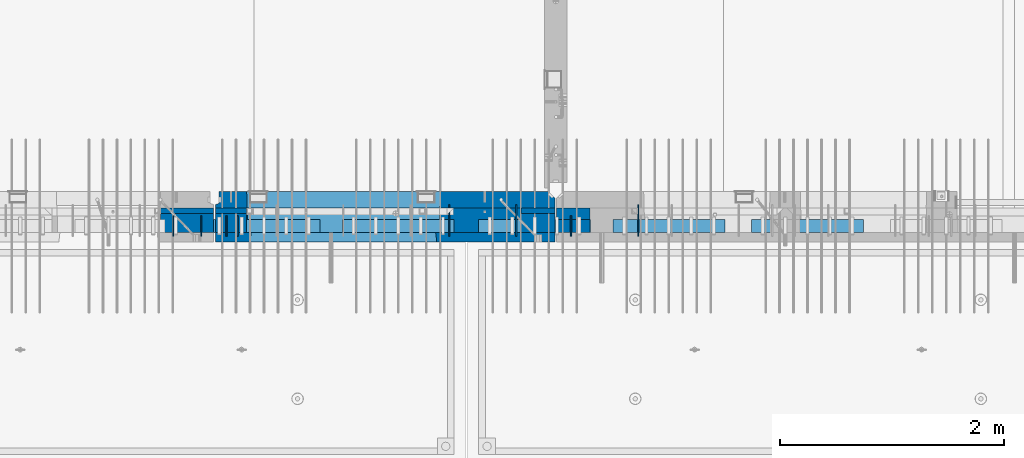
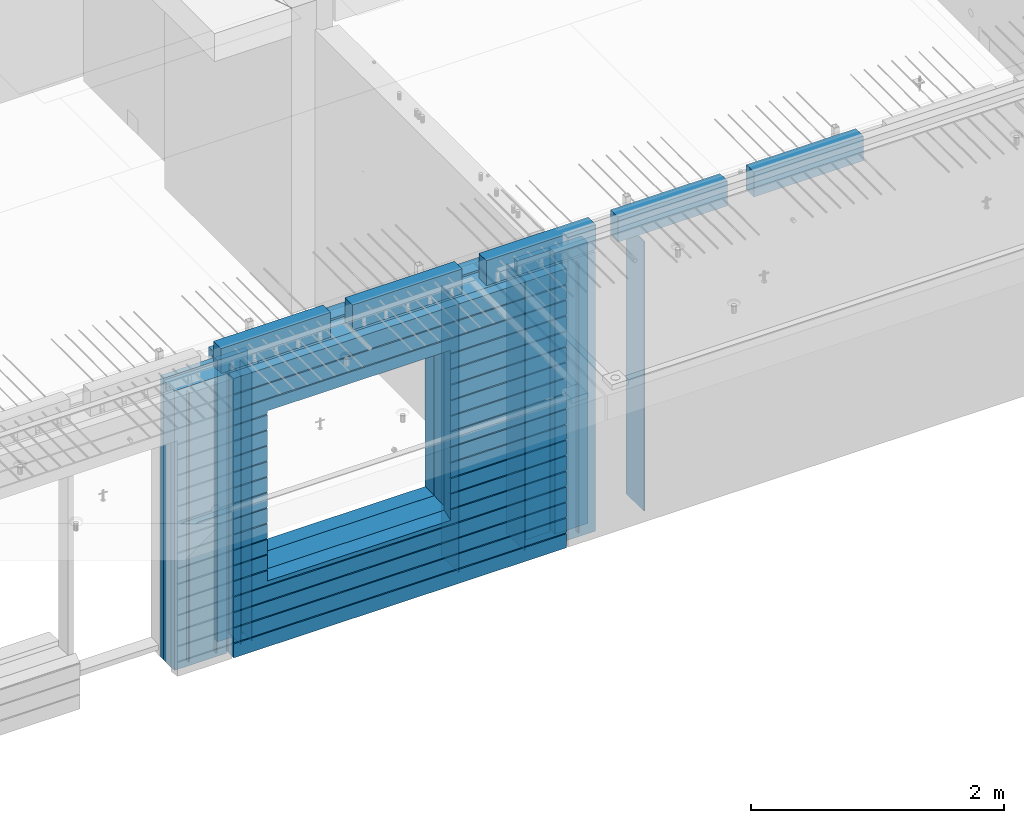
# One storey, part 233 of 352: 24 walls, 10 elements without a shape of their own.
"""IFC2X3 building model written with IfcOpenShell, lengths in millimetres."""

from ifc_helpers import new_model, si_unit, frame, origin_with_axes, place, context, subcontext, project, spatial, faceted_brep, material, type_object, element, aggregate, save


model = new_model("IFC2X3")

# Units and contexts
model_context = context("Model", 3, precision=1e-05, world=origin_with_axes())
body_context = subcontext(model_context, "Body", "Model", "MODEL_VIEW")
ifc_project = project(units=[si_unit("LENGTHUNIT", "METRE", prefix="MILLI"), si_unit("AREAUNIT", "SQUARE_METRE"), si_unit("VOLUMEUNIT", "CUBIC_METRE"), si_unit("MASSUNIT", "GRAM", prefix="KILO"), si_unit("TIMEUNIT", "SECOND"), si_unit("PLANEANGLEUNIT", "RADIAN"), si_unit("SOLIDANGLEUNIT", "STERADIAN"), si_unit("THERMODYNAMICTEMPERATUREUNIT", "DEGREE_CELSIUS"), si_unit("LUMINOUSINTENSITYUNIT", "LUMEN")], contexts=[model_context])

# Site, building, storey
site_placement = place(None, origin_with_axes())
site = spatial("IfcSite", under=ifc_project, at=site_placement, CompositionType="ELEMENT")
building_placement = place(site_placement, origin_with_axes())
building = spatial("IfcBuilding", under=site, at=building_placement, CompositionType="ELEMENT")
storey_placement = place(building_placement, origin_with_axes())
storey = spatial("IfcBuildingStorey", under=building, at=storey_placement, Name="6", CompositionType="ELEMENT", Elevation=0.0)

# Assembly, walls
assembly_1_placement = place(storey_placement, origin_with_axes())
assembly_1 = element("IfcElementAssembly", 1, at=assembly_1_placement, inside=storey, AssemblyPlace="NOTDEFINED", PredefinedType="REINFORCEMENT_UNIT")
ifc_material_1 = material(Name="Undefined")
wall_type_1 = type_object("IfcWallType", PredefinedType="NOTDEFINED")
wall_1_placement = place(assembly_1_placement, frame((25665.0, 7780.0, 98115.0), z_axis=(0.0, 0.0, 1.0), x_axis=(0.0, -1.0, 0.0)))
wall_1 = element("IfcWall", 2, at=wall_1_placement, type_object=wall_type_1, material=ifc_material_1, Name="(PD)", context=body_context, shape_type="Brep", body=[
    faceted_brep([(0.0, 5.0, -1300.0), (0.0, 5.0, 1300.0), (180.0, 5.0, 1300.0), (180.0, 5.0, -1300.0), (0.0, -5.0, 1300.0), (180.0, -5.0, 1300.0), (0.0, -5.0, -1300.0), (180.0, -5.0, -1300.0)], [[[0, 1, 2, 3]], [[1, 4, 5, 2]], [[4, 6, 7, 5]], [[6, 0, 3, 7]], [[5, 7, 3, 2]], [[6, 4, 1, 0]]]),
])
wall_2_placement = place(assembly_1_placement, frame((25765.0, 7780.0, 98115.0), z_axis=(0.0, 0.0, 1.0), x_axis=(0.0, -1.0, 0.0)))
wall_2 = element("IfcWall", 3, at=wall_2_placement, type_object=wall_type_1, material=ifc_material_1, Name="(PD)", context=body_context, shape_type="Brep", body=[
    faceted_brep([(0.0, 5.0, -1300.0), (0.0, 5.0, 1300.0), (180.0, 5.0, 1300.0), (180.0, 5.0, -1300.0), (0.0, -5.0, 1300.0), (180.0, -5.0, 1300.0), (0.0, -5.0, -1300.0), (180.0, -5.0, -1300.0)], [[[0, 1, 2, 3]], [[1, 4, 5, 2]], [[4, 6, 7, 5]], [[6, 0, 3, 7]], [[5, 7, 3, 2]], [[6, 4, 1, 0]]]),
])
wall_3_placement = place(assembly_1_placement, frame((28255.0, 7880.0, 98115.0), z_axis=(0.0, 0.0, 1.0), x_axis=(0.0, -1.0, 0.0)))
wall_3 = element("IfcWall", 4, at=wall_3_placement, type_object=wall_type_1, material=ifc_material_1, Name="(PD)", context=body_context, shape_type="Brep", body=[
    faceted_brep([(0.0, 5.0, -1300.0), (0.0, 5.0, 1300.0), (280.0, 5.0, 1300.0), (280.0, 5.0, -1300.0), (0.0, -5.0, 1300.0), (280.0, -5.0, 1300.0), (0.0, -5.0, -1300.0), (280.0, -5.0, -1300.0)], [[[0, 1, 2, 3]], [[1, 4, 5, 2]], [[4, 6, 7, 5]], [[6, 0, 3, 7]], [[5, 7, 3, 2]], [[6, 4, 1, 0]]]),
])

assembly_2_placement = place(storey_placement, origin_with_axes())
assembly_2 = element("IfcElementAssembly", 5, at=assembly_2_placement, inside=storey, AssemblyPlace="NOTDEFINED", PredefinedType="REINFORCEMENT_UNIT")
wall_4_placement = place(assembly_2_placement, frame((28745.0021834468, 7780.0, 98115.0), z_axis=(0.0, 0.0, 1.0), x_axis=(0.0, -1.0, 0.0)))
wall_4 = element("IfcWall", 6, at=wall_4_placement, type_object=wall_type_1, material=ifc_material_1, Name="(PD)", context=body_context, shape_type="Brep", body=[
    faceted_brep([(0.0, 5.0, -1300.0), (0.0, 5.0, 1300.0), (180.0, 5.0, 1300.0), (180.0, 5.0, -1300.0), (0.0, -5.0, 1300.0), (180.0, -5.0, 1300.0), (0.0, -5.0, -1300.0), (180.0, -5.0, -1300.0)], [[[0, 1, 2, 3]], [[1, 4, 5, 2]], [[4, 6, 7, 5]], [[6, 0, 3, 7]], [[5, 7, 3, 2]], [[6, 4, 1, 0]]]),
])
wall_5_placement = place(assembly_2_placement, frame((29345.0021834468, 7880.0, 98115.0), z_axis=(0.0, 0.0, 1.0), x_axis=(0.0, -1.0, 0.0)))
wall_5 = element("IfcWall", 7, at=wall_5_placement, type_object=wall_type_1, material=ifc_material_1, Name="(PD)", context=body_context, shape_type="Brep", body=[
    faceted_brep([(0.0, 5.0, -1300.0), (0.0, 5.0, 1300.0), (280.0, 5.0, 1300.0), (280.0, 5.0, -1300.0), (0.0, -5.0, 1300.0), (280.0, -5.0, 1300.0), (0.0, -5.0, -1300.0), (280.0, -5.0, -1300.0)], [[[0, 1, 2, 3]], [[1, 4, 5, 2]], [[4, 6, 7, 5]], [[6, 0, 3, 7]], [[5, 7, 3, 2]], [[6, 4, 1, 0]]]),
])

assembly_3_placement = place(storey_placement, origin_with_axes())
assembly_3 = element("IfcElementAssembly", 8, at=assembly_3_placement, inside=storey, AssemblyPlace="NOTDEFINED", PredefinedType="REINFORCEMENT_UNIT")
wall_6_placement = place(assembly_3_placement, frame((25190.0, 7780.0, 98115.0), z_axis=(0.0, 0.0, 1.0), x_axis=(0.0, -1.0, 0.0)))
wall_6 = element("IfcWall", 9, at=wall_6_placement, type_object=wall_type_1, material=ifc_material_1, Name="(PD)", context=body_context, shape_type="Brep", body=[
    faceted_brep([(0.0, 5.0, -1300.0), (0.0, 5.0, 1300.0), (180.0, 5.0, 1300.0), (180.0, 5.0, -1300.0), (0.0, -5.0, 1300.0), (180.0, -5.0, 1300.0), (0.0, -5.0, -1300.0), (180.0, -5.0, -1300.0)], [[[0, 1, 2, 3]], [[1, 4, 5, 2]], [[4, 6, 7, 5]], [[6, 0, 3, 7]], [[5, 7, 3, 2]], [[6, 4, 1, 0]]]),
])
wall_7_placement = place(assembly_3_placement, frame((25440.0, 7780.0, 98115.0), z_axis=(0.0, 0.0, 1.0), x_axis=(0.0, -1.0, 0.0)))
wall_7 = element("IfcWall", 10, at=wall_7_placement, type_object=wall_type_1, material=ifc_material_1, Name="(PD)", context=body_context, shape_type="Brep", body=[
    faceted_brep([(0.0, 5.0, -1300.0), (0.0, 5.0, 1300.0), (180.0, 5.0, 1300.0), (180.0, 5.0, -1300.0), (0.0, -5.0, 1300.0), (180.0, -5.0, 1300.0), (0.0, -5.0, -1300.0), (180.0, -5.0, -1300.0)], [[[0, 1, 2, 3]], [[1, 4, 5, 2]], [[4, 6, 7, 5]], [[6, 0, 3, 7]], [[5, 7, 3, 2]], [[6, 4, 1, 0]]]),
])

# Wall
wall_8_placement = place(assembly_1_placement, frame((27655.0, 7880.0, 98115.0), z_axis=(0.0, 0.0, 1.0), x_axis=(0.0, -1.0, 0.0)))
wall_8 = element("IfcWall", 11, at=wall_8_placement, type_object=wall_type_1, material=ifc_material_1, Name="(PD)", context=body_context, shape_type="Brep", body=[
    faceted_brep([(0.0, 5.0, -1300.0), (0.0, 5.0, 1300.0), (280.0, 5.0, 1300.0), (280.0, 5.0, -1300.0), (0.0, -5.0, 1300.0), (280.0, -5.0, 1300.0), (0.0, -5.0, -1300.0), (280.0, -5.0, -1300.0)], [[[0, 1, 2, 3]], [[1, 4, 5, 2]], [[4, 6, 7, 5]], [[6, 0, 3, 7]], [[5, 7, 3, 2]], [[6, 4, 1, 0]]]),
])

# Assemblies, walls
assembly_4_placement = place(storey_placement, origin_with_axes())
assembly_4 = element("IfcElementAssembly", 12, at=assembly_4_placement, inside=storey, AssemblyPlace="NOTDEFINED", PredefinedType="REINFORCEMENT_UNIT")
assembly_5_placement = place(assembly_4_placement, origin_with_axes())
assembly_5 = element("IfcElementAssembly", 13, at=assembly_5_placement, Name="Steel Assembly", AssemblyPlace="NOTDEFINED", PredefinedType="NOTDEFINED")
ifc_material_2 = material()
wall_type_2 = type_object("IfcWallType", PredefinedType="NOTDEFINED")
wall_9_placement = place(assembly_5_placement, frame((26699.9998568133, 7690.00021946163, 99590.0), z_axis=(0.0, 0.0, 1.0), x_axis=(1.0, 0.0, 0.0)))
wall_9 = element("IfcWall", 14, at=wall_9_placement, type_object=wall_type_2, material=ifc_material_2, context=body_context, shape_type="Brep", body=[
    faceted_brep([(0.0, 60.0, -120.0), (0.0, 60.0, 120.0), (1000.0, 60.0, 120.0), (1000.0, 60.0, -120.0), (0.0, -60.0, 120.0), (1000.0, -60.0, 120.0), (0.0, -60.0, -120.0), (1000.0, -60.0, -120.0)], [[[0, 1, 2, 3]], [[1, 4, 5, 2]], [[4, 6, 7, 5]], [[6, 0, 3, 7]], [[5, 7, 3, 2]], [[6, 4, 1, 0]]]),
])
aggregate(assembly_5, [wall_9])
assembly_6_placement = place(assembly_4_placement, origin_with_axes())
assembly_6 = element("IfcElementAssembly", 15, at=assembly_6_placement, Name="Steel Assembly", AssemblyPlace="NOTDEFINED", PredefinedType="NOTDEFINED")
aggregate(assembly_4, [assembly_6, assembly_5])
wall_10_placement = place(assembly_6_placement, frame((25499.9998568133, 7690.00021946163, 99590.0), z_axis=(0.0, 0.0, 1.0), x_axis=(1.0, 0.0, 0.0)))
wall_10 = element("IfcWall", 16, at=wall_10_placement, type_object=wall_type_2, material=ifc_material_2, context=body_context, shape_type="Brep", body=[
    faceted_brep([(0.0, 60.0, -120.0), (0.0, 60.0, 120.0), (1000.0, 60.0, 120.0), (1000.0, 60.0, -120.0), (0.0, -60.0, 120.0), (1000.0, -60.0, 120.0), (0.0, -60.0, -120.0), (1000.0, -60.0, -120.0)], [[[0, 1, 2, 3]], [[1, 4, 5, 2]], [[4, 6, 7, 5]], [[6, 0, 3, 7]], [[5, 7, 3, 2]], [[6, 4, 1, 0]]]),
])
aggregate(assembly_6, [wall_10])

assembly_7_placement = place(storey_placement, origin_with_axes())
assembly_7 = element("IfcElementAssembly", 17, at=assembly_7_placement, inside=storey, AssemblyPlace="NOTDEFINED", PredefinedType="REINFORCEMENT_UNIT")
assembly_8_placement = place(assembly_7_placement, origin_with_axes())
assembly_8 = element("IfcElementAssembly", 18, at=assembly_8_placement, Name="Steel Assembly", AssemblyPlace="NOTDEFINED", PredefinedType="NOTDEFINED")
wall_11_placement = place(assembly_8_placement, frame((30359.9998568133, 7690.00021946163, 99590.0), z_axis=(0.0, 0.0, 1.0), x_axis=(1.0, 0.0, 0.0)))
wall_11 = element("IfcWall", 19, at=wall_11_placement, type_object=wall_type_2, material=ifc_material_2, context=body_context, shape_type="Brep", body=[
    faceted_brep([(0.0, 60.0, -120.0), (0.0, 60.0, 120.0), (1000.0, 60.0, 120.0), (1000.0, 60.0, -120.0), (0.0, -60.0, 120.0), (1000.0, -60.0, 120.0), (0.0, -60.0, -120.0), (1000.0, -60.0, -120.0)], [[[0, 1, 2, 3]], [[1, 4, 5, 2]], [[4, 6, 7, 5]], [[6, 0, 3, 7]], [[5, 7, 3, 2]], [[6, 4, 1, 0]]]),
])
aggregate(assembly_8, [wall_11])
assembly_9_placement = place(assembly_7_placement, origin_with_axes())
assembly_9 = element("IfcElementAssembly", 20, at=assembly_9_placement, Name="Steel Assembly", AssemblyPlace="NOTDEFINED", PredefinedType="NOTDEFINED")
wall_12_placement = place(assembly_9_placement, frame((29119.9998568133, 7690.00021946163, 99590.0), z_axis=(0.0, 0.0, 1.0), x_axis=(1.0, 0.0, 0.0)))
wall_12 = element("IfcWall", 21, at=wall_12_placement, type_object=wall_type_2, material=ifc_material_2, context=body_context, shape_type="Brep", body=[
    faceted_brep([(0.0, 60.0, -120.0), (0.0, 60.0, 120.0), (1000.0, 60.0, 120.0), (1000.0, 60.0, -120.0), (0.0, -60.0, 120.0), (1000.0, -60.0, 120.0), (0.0, -60.0, -120.0), (1000.0, -60.0, -120.0)], [[[0, 1, 2, 3]], [[1, 4, 5, 2]], [[4, 6, 7, 5]], [[6, 0, 3, 7]], [[5, 7, 3, 2]], [[6, 4, 1, 0]]]),
])
aggregate(assembly_9, [wall_12])
assembly_10_placement = place(assembly_7_placement, origin_with_axes())
assembly_10 = element("IfcElementAssembly", 22, at=assembly_10_placement, Name="Steel Assembly", AssemblyPlace="NOTDEFINED", PredefinedType="NOTDEFINED")
aggregate(assembly_7, [assembly_10, assembly_9, assembly_8])
wall_13_placement = place(assembly_10_placement, frame((27919.9998568133, 7690.00021946163, 99590.0), z_axis=(0.0, 0.0, 1.0), x_axis=(1.0, 0.0, 0.0)))
wall_13 = element("IfcWall", 23, at=wall_13_placement, type_object=wall_type_2, material=ifc_material_2, context=body_context, shape_type="Brep", body=[
    faceted_brep([(0.0, 60.0, -120.0), (0.0, 60.0, 120.0), (1000.0, 60.0, 120.0), (1000.0, 60.0, -120.0), (0.0, -60.0, 120.0), (1000.0, -60.0, 120.0), (0.0, -60.0, -120.0), (1000.0, -60.0, -120.0)], [[[0, 1, 2, 3]], [[1, 4, 5, 2]], [[4, 6, 7, 5]], [[6, 0, 3, 7]], [[5, 7, 3, 2]], [[6, 4, 1, 0]]]),
])
aggregate(assembly_10, [wall_13])

# Wall
ifc_material_3 = material(Name="CONCRETE/C35/45")
wall_type_3 = type_object("IfcWallType", PredefinedType="NOTDEFINED")
wall_14_placement = place(assembly_1_placement, frame((28600.0, 7925.0, 98112.5), z_axis=(0.0, 0.0, 1.0), x_axis=(-1.0, 3.00000001838171e-08, 0.0)))
wall_14 = element("IfcWall", 24, at=wall_14_placement, type_object=wall_type_3, material=ifc_material_3, context=body_context, shape_type="Brep", body=[
    faceted_brep([(0.0, 75.0, 1357.5), (0.0, 75.0, -1357.5), (0.0, -15.0, -1357.5), (0.0, -15.0, 1357.5), (60.0, -75.0, -1357.5), (3035.00000000003, 75.0, -1357.5), (3035.00000000003, 45.0, -1357.5), (3002.5, 32.0, -1357.5), (3002.5, -75.0, -1357.5), (60.0, -75.0, 1357.5), (3035.00000000003, 45.0, 1357.5), (3035.00000000003, 75.0, 1357.5), (3002.5, -75.0, 1357.5), (3002.5, 32.0, 1357.5), (2755.00051719707, -75.0, -682.5), (1025.00051719707, -75.0, -682.5), (1025.00051719707, -75.0, 952.5), (2755.00051719707, -75.0, 952.5), (2750.94646314301, 75.0, -678.445945945947), (1029.05457125112, 75.0, -678.445945945947), (1029.05457125112, 75.0, 948.445945945947), (2750.94646314301, 75.0, 948.445945945947)], [[[0, 1, 2, 3]], [[4, 2, 1, 5, 6, 7, 8]], [[3, 2, 4, 9]], [[10, 11, 0, 3, 9, 12, 13]], [[5, 11, 10, 6]], [[13, 7, 6, 10]], [[12, 8, 7, 13]], [[9, 4, 8, 12], [14, 15, 16, 17]], [[14, 18, 19, 15]], [[15, 19, 20, 16]], [[1, 0, 11, 5], [18, 21, 20, 19]], [[16, 20, 21, 17]], [[18, 14, 17, 21]]]),
])

wall_type_4 = type_object("IfcWallType", PredefinedType="NOTDEFINED")
wall_15_placement = place(assembly_2_placement, frame((28915.0000381475, 7800.0, 98112.5), z_axis=(0.0, 0.0, 1.0), x_axis=(-1.0, 3.00000001838171e-08, 0.0)))
wall_15 = element("IfcWall", 25, at=wall_15_placement, type_object=wall_type_4, material=ifc_material_3, context=body_context, shape_type="Brep", body=[
    faceted_brep([(0.0, 50.0, -1357.5), (0.0, 50.0, 1357.5), (300.001908754726, 50.0, 1357.5), (300.001908754726, 50.0, -1357.5), (0.0, -50.0, 1357.5), (300.001908754726, -50.0, 1357.5), (0.0, -50.0, -1357.5), (300.001908754726, -50.0, -1357.5)], [[[0, 1, 2, 3]], [[1, 4, 5, 2]], [[4, 6, 7, 5]], [[6, 0, 3, 7]], [[5, 7, 3, 2]], [[6, 4, 1, 0]]]),
])

ifc_material_4 = material(Name="SPU")
wall_type_5 = type_object("IfcWallType", PredefinedType="NOTDEFINED")
wall_16_placement = place(assembly_2_placement, frame((28915.0000381475, 7690.0, 98102.5), z_axis=(0.0, 0.0, 1.0), x_axis=(-1.0, 3.00000001838171e-08, 0.0)))
wall_16 = element("IfcWall", 26, at=wall_16_placement, type_object=wall_type_5, material=ifc_material_4, context=body_context, shape_type="Brep", body=[
    faceted_brep([(0.0, 60.0, -1347.5), (0.0, 60.0, 1347.5), (300.001908754726, 60.0, 1347.5), (300.001908754726, 60.0, -1347.5), (0.0, -60.0, 1347.5), (300.001908754726, -60.0, 1347.5), (0.0, -60.0, -1347.5), (300.001908754726, -60.0, -1347.5)], [[[0, 1, 2, 3]], [[1, 4, 5, 2]], [[4, 6, 7, 5]], [[6, 0, 3, 7]], [[5, 7, 3, 2]], [[6, 4, 1, 0]]]),
])

aggregate(assembly_2, [wall_16, wall_15, wall_4, wall_5])

wall_type_6 = type_object("IfcWallType", PredefinedType="NOTDEFINED")
wall_17_placement = place(assembly_1_placement, frame((28600.0000381475, 7825.0, 98112.5), z_axis=(0.0, 0.0, 1.0), x_axis=(-1.0, 3.00000001838171e-08, 0.0)))
wall_17 = element("IfcWall", 27, at=wall_17_placement, type_object=wall_type_6, material=ifc_material_3, context=body_context, shape_type="Brep", body=[
    faceted_brep([(0.0, 25.0, -1357.5), (0.0, 25.0, 1357.5), (300.001908754726, 25.0, 1357.5), (300.001908754726, 25.0, -1357.5), (0.0, -25.0, 1357.5), (300.001908754726, -25.0, 1357.5), (0.0, -25.0, -1357.5), (300.001908754726, -25.0, -1357.5)], [[[0, 1, 2, 3]], [[1, 4, 5, 2]], [[4, 6, 7, 5]], [[6, 0, 3, 7]], [[5, 7, 3, 2]], [[6, 4, 1, 0]]]),
])

wall_18_placement = place(assembly_3_placement, frame((25550.0000381475, 7825.00011629906, 98112.5), z_axis=(0.0, 0.0, 1.0), x_axis=(-1.0, 3.00000001838171e-08, 0.0)))
wall_18 = element("IfcWall", 28, at=wall_18_placement, type_object=wall_type_6, material=ifc_material_3, context=body_context, shape_type="Brep", body=[
    faceted_brep([(0.0, 25.0, -1357.5), (0.0, 25.0, 1357.5), (475.001908754726, 25.0, 1357.5), (475.001908754726, 25.0, -1357.5), (0.0, -25.0, 1357.5), (475.001908754726, -25.0, 1357.5), (0.0, -25.0, -1357.5), (475.001908754726, -25.0, -1357.5)], [[[0, 1, 2, 3]], [[1, 4, 5, 2]], [[4, 6, 7, 5]], [[6, 0, 3, 7]], [[5, 7, 3, 2]], [[6, 4, 1, 0]]]),
])

wall_19_placement = place(assembly_1_placement, frame((25845.0000381475, 7825.0, 98112.5), z_axis=(0.0, 0.0, 1.0), x_axis=(-1.0, 3.00000001838171e-08, 0.0)))
wall_19 = element("IfcWall", 29, at=wall_19_placement, type_object=wall_type_6, material=ifc_material_3, context=body_context, shape_type="Brep", body=[
    faceted_brep([(0.0, 25.0, -1357.5), (0.0, 25.0, 1357.5), (280.001908754726, 25.0, 1357.5), (280.001908754726, 25.0, -1357.5), (0.0, -25.0, 1357.5), (280.001908754726, -25.0, 1357.5), (0.0, -25.0, -1357.5), (280.001908754726, -25.0, -1357.5)], [[[0, 1, 2, 3]], [[1, 4, 5, 2]], [[4, 6, 7, 5]], [[6, 0, 3, 7]], [[5, 7, 3, 2]], [[6, 4, 1, 0]]]),
])

wall_type_7 = type_object("IfcWallType", PredefinedType="NOTDEFINED")
wall_20_placement = place(assembly_3_placement, frame((25550.0000381475, 7715.00011629906, 98102.5), z_axis=(0.0, 0.0, 1.0), x_axis=(-1.0, 3.00000001838171e-08, 0.0)))
wall_20 = element("IfcWall", 30, at=wall_20_placement, type_object=wall_type_7, material=ifc_material_4, context=body_context, shape_type="Brep", body=[
    faceted_brep([(0.0, 85.0, -1347.5), (0.0, 85.0, 1347.5), (475.001908754726, 85.0, 1347.5), (475.001908754726, 85.0, -1347.5), (0.0, -85.0, 1347.5), (475.001908754726, -85.0, 1347.5), (0.0, -85.0, -1347.5), (475.001908754726, -85.0, -1347.5)], [[[0, 1, 2, 3]], [[1, 4, 5, 2]], [[4, 6, 7, 5]], [[6, 0, 3, 7]], [[5, 7, 3, 2]], [[6, 4, 1, 0]]]),
])

aggregate(assembly_3, [wall_20, wall_18, wall_6, wall_7])

wall_21_placement = place(assembly_1_placement, frame((28600.0000381475, 7715.0, 98102.5), z_axis=(0.0, 0.0, 1.0), x_axis=(-1.0, 3.00000001838171e-08, 0.0)))
wall_21 = element("IfcWall", 31, at=wall_21_placement, type_object=wall_type_7, material=ifc_material_4, context=body_context, shape_type="Brep", body=[
    faceted_brep([(0.0, 85.0, -1347.5), (0.0, 85.0, 1347.5), (300.001908754726, 85.0, 1347.5), (300.001908754726, 85.0, -1347.5), (0.0, -85.0, 1347.5), (300.001908754726, -85.0, 1347.5), (0.0, -85.0, -1347.5), (300.001908754726, -85.0, -1347.5)], [[[0, 1, 2, 3]], [[1, 4, 5, 2]], [[4, 6, 7, 5]], [[6, 0, 3, 7]], [[5, 7, 3, 2]], [[6, 4, 1, 0]]]),
])

wall_22_placement = place(assembly_1_placement, frame((25845.0000381475, 7715.0, 98102.5), z_axis=(0.0, 0.0, 1.0), x_axis=(-1.0, 3.00000001838171e-08, 0.0)))
wall_22 = element("IfcWall", 32, at=wall_22_placement, type_object=wall_type_7, material=ifc_material_4, context=body_context, shape_type="Brep", body=[
    faceted_brep([(0.0, 85.0, -1347.5), (0.0, 85.0, 1347.5), (280.001908754726, 85.0, 1347.5), (280.001908754726, 85.0, -1347.5), (0.0, -85.0, 1347.5), (280.001908754726, -85.0, 1347.5), (0.0, -85.0, -1347.5), (280.001908754726, -85.0, -1347.5)], [[[0, 1, 2, 3]], [[1, 4, 5, 2]], [[4, 6, 7, 5]], [[6, 0, 3, 7]], [[5, 7, 3, 2]], [[6, 4, 1, 0]]]),
])

ifc_material_5 = material(Name="CONCRETE/C30/37")
wall_type_8 = type_object("IfcWallType", PredefinedType="NOTDEFINED")
wall_23_placement = place(assembly_1_placement, frame((28600.0, 7587.5, 98102.5), z_axis=(0.0, 0.0, 1.0), x_axis=(-1.0, 3.00000001838171e-08, 0.0)))
wall_23 = element("IfcWall", 33, at=wall_23_placement, type_object=wall_type_8, material=ifc_material_5, context=body_context, shape_type="Brep", body=[
    faceted_brep([(3.63797880709171e-12, 32.4999991119639, 1050.00000040043), (3035.0, 32.4999991119785, 1050.00000040044), (3035.0, 32.4999992499725, 1039.99999999921), (3.63797880709171e-12, 32.4999992499725, 1039.99999999921), (0.0, 42.5, 1051.99999988925), (3035.0, 42.5, 1051.99999988925), (0.0, 42.5, 1187.99999994476), (3035.0, 42.5, 1187.99999994476), (-3.63797880709171e-12, 32.499999249967, 1189.99999999923), (3035.0, 32.4999992499634, 1189.99999999921), (-3.63797880709171e-12, 32.4999991119576, 1200.00000040043), (3035.0, 32.4999991119703, 1200.00000040044), (0.0, 42.5, 1201.99999988925), (3035.0, 42.5, 1201.99999988925), (0.0, 42.5, 1347.5), (3035.0, 42.5, 1347.5), (0.0, -42.5, 1347.5), (3035.0, -42.5, 1347.5), (0.0, -42.5, -1347.5), (0.0, 42.5, -1347.5), (3035.0, 42.5, -1347.5), (3035.0, -42.5, -1347.5), (0.0, 42.5, -1212.00000005524), (3035.0, 42.5, -1212.00000005524), (0.0, 32.4999992501671, -1210.00000000079), (3035.0, 32.4999992501644, -1210.0000000008), (0.0, 32.4999991121604, -1199.99999959957), (3035.0, 32.4999991121604, -1199.99999959957), (0.0, 42.5, -1198.00000011075), (3035.0, 42.5, -1198.00000011075), (0.0, 42.5, -1062.00000005522), (3035.0, 42.5, -1062.00000005522), (0.0, 32.4999992506973, -1060.00000000076), (3035.0, 32.4999992506928, -1060.00000000079), (0.0, 32.4999991126861, -1049.99999959956), (3035.0, 32.4999991126924, -1049.99999959956), (0.0, 42.5, -1048.00000011074), (3035.0, 42.5, -1048.00000011074), (0.0, 42.5, -912.000000055254), (3035.0, 42.5, -912.000000055254), (0.0, 32.4999992512376, -910.000000000786), (3035.0, 32.4999992512339, -910.000000000815), (0.0, 32.499999113239, -899.99999959959), (3035.0, 32.4999991132327, -899.99999959959), (0.0, 42.5, -898.000000110769), (3035.0, 42.5, -898.000000110769), (0.0, 42.5, -762.000000055225), (3035.0, 42.5, -762.000000055225), (0.0, 32.4999992517696, -760.000000000757), (3035.0, 32.499999251766, -760.000000000786), (0.0, 32.4999991137702, -749.99999959956), (3035.0, 32.4999991137656, -749.99999959956), (0.0, 42.5, -748.00000011074), (3035.0, 42.5, -748.00000011074), (3035.0, 42.5, 901.999999889245), (3035.0, 32.4999991119894, 900.00000040044), (2723.82404650436, 32.4999991119894, 900.00000040044), (2725.00051719707, 42.5, 901.999999889245), (3035.0, 32.4999992499834, 889.999999999214), (2723.82404652059, 32.4999992499834, 889.999999999214), (3035.0, 42.5, 887.999999944761), (2725.00051719707, 42.5, 887.999999944761), (3035.0, 42.5, 751.999999889245), (2725.00051719707, 42.5, 751.999999889245), (3035.0, 32.4999991119967, 750.000000400425), (2723.82404650436, 32.4999991119967, 750.000000400425), (3035.0, 32.4999992499961, 739.9999999992), (2723.82404652059, 32.4999992499961, 739.9999999992), (3035.0, 42.5, 737.999999944761), (2725.00051719707, 42.5, 737.999999944761), (3035.0, 42.5, 601.99999988926), (2725.00051719707, 42.5, 601.99999988926), (3035.0, 32.4999991120212, 600.000000400454), (2723.82404650436, 32.4999991120212, 600.000000400454), (3035.0, 32.4999992500161, 589.999999999229), (2723.8240465206, 32.4999992500161, 589.999999999229), (3035.0, 42.5, 587.999999944775), (2725.00051719707, 42.5, 587.999999944775), (3035.0, 42.5, 451.999999889231), (2725.00051719707, 42.5, 451.999999889231), (3035.0, 32.4999991120285, 450.000000400425), (2723.82404650436, 32.4999991120285, 450.000000400425), (3035.0, 32.4999992500234, 439.9999999992), (2723.8240465206, 32.4999992500234, 439.9999999992), (3035.0, 42.5, 437.999999944746), (2725.00051719707, 42.5, 437.999999944746), (3035.0, 42.5, 301.999999889245), (2725.00051719707, 42.5, 301.999999889245), (3035.0, 32.4999991120458, 300.00000040044), (2723.82404650437, 32.4999991120458, 300.00000040044), (3035.0, 32.4999992500389, 289.999999999214), (2723.8240465206, 32.4999992500389, 289.999999999214), (3035.0, 42.5, 287.999999944761), (2725.00051719707, 42.5, 287.999999944761), (3035.0, 42.5, 151.99999988926), (2725.00051719707, 42.5, 151.99999988926), (3035.0, 32.4999991120585, 150.000000400454), (2723.82404650437, 32.4999991120585, 150.000000400454), (3035.0, 32.4999992500534, 139.999999999229), (2723.8240465206, 32.4999992500534, 139.999999999229), (3035.0, 42.5, 137.999999944775), (2725.00051719707, 42.5, 137.999999944775), (3035.0, 42.5, 1.99999988924537), (2725.00051719707, 42.5, 1.99999988924537), (3035.0, 32.4999992522926, -610.0000000008), (3035.0, 42.5, -612.000000055239), (2725.00051719707, 42.5, -612.000000055239), (2723.82404652087, 32.4999992522926, -610.0000000008), (3035.0, 32.4999991142904, -599.999999599575), (2723.82404650463, 32.4999991142904, -599.999999599575), (3035.0, 42.5, -598.000000110755), (2725.00051719707, 42.5, -598.000000110755), (3035.0, 42.5, -462.000000055239), (2725.00051719707, 42.5, -462.000000055239), (3035.0, 32.4999992528319, -460.0000000008), (2723.82404652093, 32.4999992528319, -460.0000000008), (3035.0, 32.4999991148297, -449.999999599575), (2723.82404650469, 32.4999991148297, -449.999999599575), (3035.0, 42.5, -448.000000110755), (2725.00051719707, 42.5, -448.000000110755), (3035.0, 42.5, -312.000000055254), (2725.00051719707, 42.5, -312.000000055254), (3035.0, 32.4999992533585, -310.000000000815), (2723.82404652099, 32.4999992533585, -310.000000000815), (3035.0, 32.4999991153563, -299.99999959959), (2723.82404650475, 32.4999991153563, -299.99999959959), (3035.0, 42.5, -298.000000110769), (2725.00051719707, 42.5, -298.000000110769), (3035.0, 42.5, -162.000000055239), (2725.00051719707, 42.499999923677, -162.000000055239), (3035.0, 32.4999992538951, -160.0000000008), (2723.82404652105, 32.4999992538951, -160.0000000008), (3035.0, 32.4999991158938, -149.999999599575), (2723.82404650482, 32.4999991158938, -149.999999599575), (3035.0, 42.5, -148.000000110755), (2725.00051719707, 42.4999999210722, -148.000000110755), (3035.0, 42.5, -12.0000000552391), (2725.00051719707, 42.5, -12.0000000552391), (3035.0, 32.4999992538906, -10.0000000008004), (2723.82404652105, 32.4999992538906, -10.0000000008004), (3035.0, 32.4999991158902, 4.00425051338971e-07), (2723.82404650482, 32.4999991158902, 4.00425051338971e-07), (3035.0, 42.5, 1037.99999994476), (0.0, 42.5, 1037.99999994476), (3.63797880709171e-12, 32.4999992499852, 889.999999999229), (3.63797880709171e-12, 32.4999991119857, 900.000000400425), (1056.17698788978, 32.4999991119894, 900.00000040044), (1056.17698787354, 32.4999992499834, 889.999999999214), (0.0, 42.5, 887.999999944761), (1055.00051719707, 42.5, 887.999999944761), (0.0, 42.5, 751.999999889245), (1055.00051719707, 42.5, 751.999999889245), (0.0, 32.4999991120039, 750.00000040044), (1056.17698788978, 32.4999991119967, 750.000000400425), (0.0, 32.4999992499997, 739.999999999229), (1056.17698787354, 32.4999992499961, 739.9999999992), (0.0, 42.5, 737.999999944761), (1055.00051719707, 42.5, 737.999999944761), (0.0, 42.5, 601.99999988926), (1055.00051719707, 42.5, 601.99999988926), (0.0, 32.4999991120094, 600.00000040044), (1056.17698788977, 32.4999991120212, 600.000000400454), (0.0, 32.499999250017, 589.999999999229), (1056.17698787354, 32.4999992500161, 589.999999999229), (0.0, 42.5, 587.999999944775), (1055.00051719707, 42.5, 587.999999944775), (0.0, 42.5, 451.999999889231), (1055.00051719707, 42.5, 451.999999889231), (0.0, 32.4999991120258, 450.000000400411), (1056.17698788977, 32.4999991120285, 450.000000400425), (0.0, 32.4999992500289, 439.999999999214), (1056.17698787354, 32.4999992500234, 439.9999999992), (0.0, 42.5, 437.999999944746), (1055.00051719707, 42.5, 437.999999944746), (0.0, 42.5, 301.999999889245), (1055.00051719707, 42.5, 301.999999889245), (-3.63797880709171e-12, 32.4999991120458, 300.00000040044), (1056.17698788977, 32.4999991120458, 300.00000040044), (-3.63797880709171e-12, 32.4999992500416, 289.999999999229), (1056.17698787353, 32.4999992500389, 289.999999999214), (0.0, 42.5, 287.999999944761), (1055.00051719707, 42.5, 287.999999944761), (0.0, 42.5, 151.99999988926), (1055.00051719707, 42.5, 151.99999988926), (0.0, 32.4999991120549, 150.00000040044), (1056.17698788977, 32.4999991120585, 150.000000400454), (0.0, 32.4999992500552, 139.999999999229), (1056.17698787353, 32.4999992500534, 139.999999999229), (0.0, 42.5, 137.999999944775), (1055.00051719707, 42.5, 137.999999944775), (0.0, 42.5, 1.99999988924537), (1055.00051719707, 42.5, 1.99999988924537), (0.0, 42.5, -12.0000000552391), (0.0, 42.5, -148.000000110755), (0.0, 32.4999991158993, -149.99999959956), (0.0, 32.4999992538978, -160.000000000757), (0.0, 42.5, -162.000000055239), (0.0, 42.5, -298.000000110769), (0.0, 32.4999991153618, -299.99999959959), (0.0, 32.4999992533649, -310.000000000786), (0.0, 42.5, -312.000000055254), (0.0, 42.5, -448.000000110755), (0.0, 32.4999991148252, -449.999999599575), (0.0, 32.4999992528365, -460.000000000771), (0.0, 42.5, -462.000000055239), (0.0, 42.5, -598.000000110755), (0.0, 32.4999991143004, -599.99999959956), (0.0, 32.4999992522971, -610.000000000771), (0.0, 42.5, -612.000000055239), (0.0, 42.5, 901.999999889245), (0.0, 32.4999991158911, 4.00425051338971e-07), (0.0, 32.4999992538942, -10.0000000007858), (1056.17698788932, 32.4999991158902, 4.00425051338971e-07), (1056.17698787308, 32.4999992538906, -10.0000000008004), (1055.00051719707, 42.5, -12.0000000552391), (1055.00051719707, 42.4999994958771, -148.000000110755), (1056.17698788932, 32.4999991158938, -149.999999599575), (1056.17698787308, 32.4999992538951, -160.0000000008), (1055.00051719707, 42.499999512519, -162.000000055239), (1055.00051719707, 42.5, -298.000000110769), (1056.17698788938, 32.4999991153563, -299.99999959959), (1056.17698787315, 32.4999992533585, -310.000000000815), (1055.00051719707, 42.5, -312.000000055254), (1055.00051719707, 42.5, -448.000000110755), (1056.17698788944, 32.4999991148297, -449.999999599575), (1056.17698787321, 32.4999992528319, -460.0000000008), (1055.00051719707, 42.5, -462.000000055239), (1055.00051719707, 42.5, -598.000000110755), (1056.1769878895, 32.4999991142904, -599.999999599575), (1056.17698787327, 32.4999992522926, -610.0000000008), (1055.00051719707, 42.5, -612.000000055239), (2725.00051719707, 42.5, -712.5), (1055.00051719707, 42.5, -712.5), (2715.00051719707, -42.5, 927.5), (2715.00051719707, -42.5, 932.5), (2725.00051719707, 42.5, 927.5), (2715.00051719707, -42.5, -662.5), (1065.00051719707, -42.5, -662.5), (1065.00051719707, -42.5, 927.5), (1065.00051719707, -42.5, 932.5), (1065.00051719707, 42.5, 927.5), (2715.00051719707, 42.5, 927.5), (1055.00051719707, 42.5, 927.5), (1055.00051719707, 42.5, 901.999999889245)], [[[0, 1, 2, 3]], [[4, 5, 1, 0]], [[5, 4, 6, 7]], [[8, 9, 7, 6]], [[10, 11, 9, 8]], [[12, 13, 11, 10]], [[14, 15, 13, 12]], [[14, 16, 17, 15]], [[18, 19, 20, 21]], [[20, 19, 22, 23]], [[24, 25, 23, 22]], [[26, 27, 25, 24]], [[28, 29, 27, 26]], [[29, 28, 30, 31]], [[32, 33, 31, 30]], [[34, 35, 33, 32]], [[36, 37, 35, 34]], [[37, 36, 38, 39]], [[40, 41, 39, 38]], [[42, 43, 41, 40]], [[44, 45, 43, 42]], [[45, 44, 46, 47]], [[48, 49, 47, 46]], [[50, 51, 49, 48]], [[52, 53, 51, 50]], [[54, 55, 56, 57]], [[55, 58, 59, 56]], [[58, 60, 61, 59]], [[60, 62, 63, 61]], [[62, 64, 65, 63]], [[64, 66, 67, 65]], [[66, 68, 69, 67]], [[68, 70, 71, 69]], [[70, 72, 73, 71]], [[72, 74, 75, 73]], [[74, 76, 77, 75]], [[76, 78, 79, 77]], [[78, 80, 81, 79]], [[80, 82, 83, 81]], [[82, 84, 85, 83]], [[84, 86, 87, 85]], [[86, 88, 89, 87]], [[88, 90, 91, 89]], [[90, 92, 93, 91]], [[92, 94, 95, 93]], [[94, 96, 97, 95]], [[96, 98, 99, 97]], [[98, 100, 101, 99]], [[100, 102, 103, 101]], [[104, 105, 106, 107]], [[108, 104, 107, 109]], [[110, 108, 109, 111]], [[112, 110, 111, 113]], [[114, 112, 113, 115]], [[116, 114, 115, 117]], [[118, 116, 117, 119]], [[120, 118, 119, 121]], [[122, 120, 121, 123]], [[124, 122, 123, 125]], [[126, 124, 125, 127]], [[128, 126, 127, 129]], [[130, 128, 129, 131]], [[132, 130, 131, 133]], [[134, 132, 133, 135]], [[136, 134, 135, 137]], [[138, 136, 137, 139]], [[140, 138, 139, 141]], [[102, 140, 141, 103]], [[100, 98, 96, 94, 92, 90, 88, 86, 84, 82, 80, 78, 76, 74, 72, 70, 68, 66, 64, 62, 60, 58, 55, 54, 142, 2, 1, 5, 7, 9, 11, 13, 15, 17, 21, 20, 23, 25, 27, 29, 31, 33, 35, 37, 39, 41, 43, 45, 47, 49, 51, 53, 105, 104, 108, 110, 112, 114, 116, 118, 120, 122, 124, 126, 128, 130, 132, 134, 136, 138, 140, 102]], [[3, 2, 142, 143]], [[144, 145, 146, 147]], [[148, 144, 147, 149]], [[150, 148, 149, 151]], [[152, 150, 151, 153]], [[154, 152, 153, 155]], [[156, 154, 155, 157]], [[158, 156, 157, 159]], [[160, 158, 159, 161]], [[162, 160, 161, 163]], [[164, 162, 163, 165]], [[166, 164, 165, 167]], [[168, 166, 167, 169]], [[170, 168, 169, 171]], [[172, 170, 171, 173]], [[174, 172, 173, 175]], [[176, 174, 175, 177]], [[178, 176, 177, 179]], [[180, 178, 179, 181]], [[182, 180, 181, 183]], [[184, 182, 183, 185]], [[186, 184, 185, 187]], [[188, 186, 187, 189]], [[190, 188, 189, 191]], [[192, 193, 194, 195, 196, 197, 198, 199, 200, 201, 202, 203, 204, 205, 206, 207, 208, 52, 50, 48, 46, 44, 42, 40, 38, 36, 34, 32, 30, 28, 26, 24, 22, 19, 18, 16, 14, 12, 10, 8, 6, 4, 0, 3, 143, 209, 145, 144, 148, 150, 152, 154, 156, 158, 160, 162, 164, 166, 168, 170, 172, 174, 176, 178, 180, 182, 184, 186, 188, 190, 210, 211]], [[211, 210, 212, 213]], [[192, 211, 213, 214]], [[193, 192, 214, 215]], [[194, 193, 215, 216]], [[195, 194, 216, 217]], [[196, 195, 217, 218]], [[197, 196, 218, 219]], [[198, 197, 219, 220]], [[199, 198, 220, 221]], [[200, 199, 221, 222]], [[201, 200, 222, 223]], [[202, 201, 223, 224]], [[203, 202, 224, 225]], [[204, 203, 225, 226]], [[205, 204, 226, 227]], [[206, 205, 227, 228]], [[207, 206, 228, 229]], [[208, 207, 229, 230]], [[231, 106, 105, 53, 52, 208, 230, 232]], [[233, 234, 235, 57, 56, 59, 61, 63, 65, 67, 69, 71, 73, 75, 77, 79, 81, 83, 85, 87, 89, 91, 93, 95, 97, 99, 101, 103, 141, 139, 137, 135, 133, 131, 129, 127, 125, 123, 121, 119, 117, 115, 113, 111, 109, 107, 106, 231, 236]], [[232, 237, 236, 231]], [[16, 18, 21, 17], [233, 236, 237, 238, 239, 234]], [[240, 241, 235, 234, 239, 242]], [[209, 143, 142, 54, 57, 235, 241, 240, 242, 243]], [[145, 209, 243, 146]], [[242, 239, 238, 237, 232, 230, 229, 228, 227, 226, 225, 224, 223, 222, 221, 220, 219, 218, 217, 216, 215, 214, 213, 212, 191, 189, 187, 185, 183, 181, 179, 177, 175, 173, 171, 169, 167, 165, 163, 161, 159, 157, 155, 153, 151, 149, 147, 146, 243]], [[210, 190, 191, 212]]]),
])

ifc_material_6 = material(Name="COS5gt")
wall_type_9 = type_object("IfcWallType", PredefinedType="NOTDEFINED")
wall_24_placement = place(assembly_1_placement, frame((28600.0, 7740.0, 98102.5), z_axis=(0.0, 0.0, 1.0), x_axis=(-1.0, 3.00000001838171e-08, 0.0)))
wall_24 = element("IfcWall", 34, at=wall_24_placement, type_object=wall_type_9, material=ifc_material_6, context=body_context, shape_type="Brep", body=[
    faceted_brep([(2755.0, 90.0, -1347.5), (2755.0, -110.0, -1347.5), (300.001870607201, -110.0, -1347.5), (300.001870607201, 90.0, -1347.5), (2755.0, 90.0, -1297.5), (300.001870607201, 90.0, -1297.5), (2755.0, 110.0, -1297.5), (300.001870607201, 110.0, -1297.5), (2755.0, 110.0, 1347.5), (2755.0, -110.0, 1347.5), (2750.94646314301, -110.0, -668.445945945947), (2745.00051719707, 110.0, -662.5), (2715.00051719707, 110.0, -662.5), (1065.00051719707, 110.0, -662.5), (1035.00051719707, 110.0, -662.5), (1029.05457125112, -110.0, -668.445945945947), (300.001870607201, -110.0, 1347.5), (1029.05457125112, -110.0, 958.445945945947), (2750.94646314301, -110.0, 958.445945945947), (2745.00051719707, 110.0, -657.5), (2745.00051719707, 110.0, 952.5), (1035.00051719707, 110.0, 952.5), (1035.00051719707, 110.0, -657.5), (300.001870607201, 110.0, 1347.5)], [[[0, 1, 2, 3]], [[4, 0, 3, 5]], [[6, 4, 5, 7]], [[8, 9, 1, 0, 4, 6]], [[10, 11, 12, 13, 14, 15]], [[1, 9, 16, 2], [10, 15, 17, 18]], [[19, 11, 10, 18, 20]], [[17, 21, 20, 18]], [[15, 14, 22, 21, 17]], [[8, 6, 7, 23], [14, 13, 12, 11, 19, 20, 21, 22]], [[9, 8, 23, 16]], [[7, 5, 3, 2, 16, 23]]]),
])

aggregate(assembly_1, [wall_21, wall_17, wall_22, wall_1, wall_2, wall_3, wall_19, wall_8, wall_23, wall_24, wall_14])

save(model, "model.ifc")
